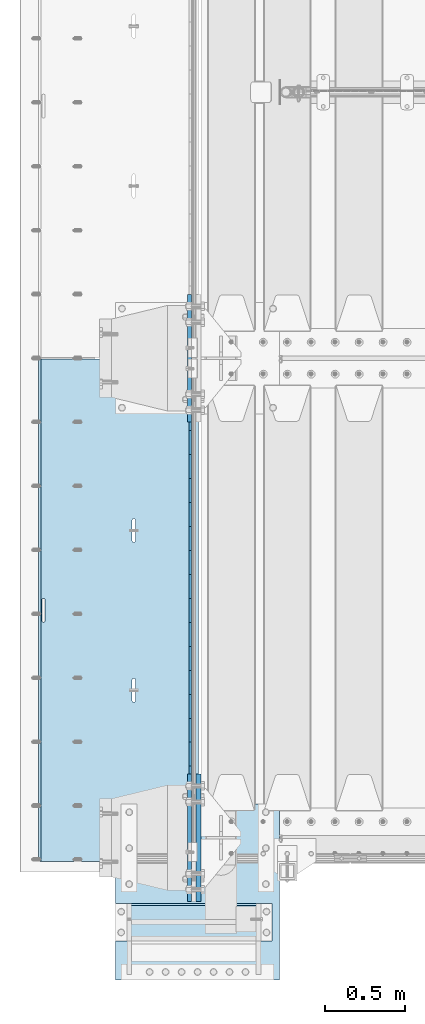
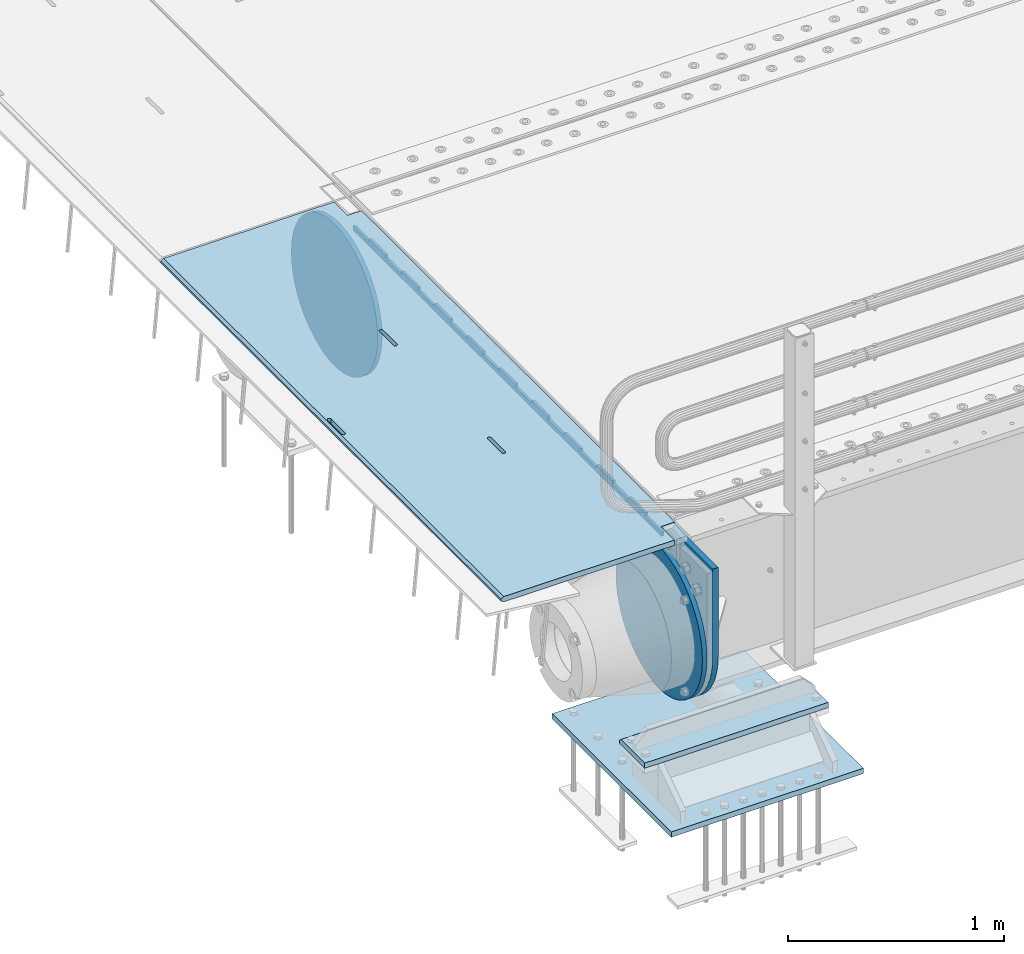
# One storey, part 161 of 208: 7 plates.
"""IFC2X3 building model written with IfcOpenShell, lengths in millimetres."""

from ifc_helpers import new_model, si_unit, frame, origin_with_axes, place, context, subcontext, project, spatial, faceted_brep, material, type_object, element, save


model = new_model("IFC2X3")

# Units and contexts
model_context = context("Model", 3, precision=1e-05, world=origin_with_axes())
body_context = subcontext(model_context, "Body", "Model", "MODEL_VIEW")
ifc_project = project(units=[si_unit("LENGTHUNIT", "METRE", prefix="MILLI"), si_unit("AREAUNIT", "SQUARE_METRE"), si_unit("VOLUMEUNIT", "CUBIC_METRE"), si_unit("MASSUNIT", "GRAM", prefix="KILO"), si_unit("TIMEUNIT", "SECOND"), si_unit("PLANEANGLEUNIT", "RADIAN"), si_unit("SOLIDANGLEUNIT", "STERADIAN"), si_unit("THERMODYNAMICTEMPERATUREUNIT", "DEGREE_CELSIUS"), si_unit("LUMINOUSINTENSITYUNIT", "LUMEN")], contexts=[model_context])

# Site, building, storey
site_placement = place(None, origin_with_axes())
site = spatial("IfcSite", under=ifc_project, at=site_placement, CompositionType="ELEMENT")
building_placement = place(site_placement, origin_with_axes())
building = spatial("IfcBuilding", under=site, at=building_placement, Name="Standard", CompositionType="ELEMENT")
storey_placement = place(building_placement, origin_with_axes())
storey = spatial("IfcBuildingStorey", under=building, at=storey_placement, Name="Undefined", CompositionType="ELEMENT", Elevation=0.0)

# Plates
ifc_material_1 = material(Name="STEEL/S355N")
plate_type_1 = type_object("IfcPlateType", PredefinedType="NOTDEFINED")
plate_1_placement = place(storey_placement, frame((-42455.0037545707, 2994.99992612933, -0.984410850183148), z_axis=(1.0000003385235e-09, -0.999999999987744, -4.95099999993936e-06), x_axis=(-0.999999999879068, -1.00000022173607e-09, -1.55519999981193e-05)))
element("IfcPlate", 1, at=plate_1_placement, inside=storey, type_object=plate_type_1, material=ifc_material_1, context=body_context, shape_type="Brep", body=[
    faceted_brep([(984.996459961352, -15.0, 1.81898940354586e-12), (999.996459960938, -4.99999999999848, 1.36424205265939e-12), (999.996459718779, -4.99999999999848, 3145.0), (984.996459719194, -15.0, 3145.0), (999.996459960938, 5.0, 1.81898940354586e-12), (984.996459960938, 15.0, 1.36424205265939e-12), (984.996459718779, 15.0, 3145.0), (999.996459718779, 5.0, 3145.0), (14.9998601691623, 15.0, 125.000024820844), (-0.000294611330900807, -0.000806902962786349, 124.999936248646), (-0.00191941577941179, 0.000806844426833264, 3020.00000492305), (14.9966216875036, 15.0, 3020.00007976653), (394.996621756974, -15.0000000032171, 2137.49999999767), (394.996621756974, 15.0, 2137.49999999767), (395.486056593785, 15.0, 2140.59016994142), (395.486056593785, -15.0000000032097, 2140.59016994142), (396.906451812771, 15.0, 2143.3778525206), (396.906451812763, -15.0000000031847, 2143.3778525206), (399.118769233428, 15.0, 2145.59016994142), (399.118769233428, -15.0000000031445, 2145.59016994142), (401.90645181248, 15.0, 2147.01056516062), (401.906451812487, -15.0000000030931, 2147.01056516062), (404.996621756189, 15.0, 2147.49999999767), (404.996621756189, -15.0000000030354, 2147.49999999767), (408.086791699985, 15.0, 2147.01056516062), (408.086791699985, -15.0000000029771, 2147.01056516062), (410.87447427927, 15.0, 2145.59016994142), (410.874474279262, -15.000000002924, 2145.59016994142), (413.086791700269, 15.0, 2143.37785252059), (413.086791700269, -15.0000000028812, 2143.37785252059), (414.507186919676, 15.0, 2140.59016994141), (414.507186919684, -15.000000002853, 2140.59016994141), (414.996621756967, 15.0, 2137.49999999766), (414.996621756967, -15.000000002842, 2137.49999999766), (414.996621766863, 15.0, 2007.49999999766), (414.996621766863, -15.0000000027658, 2007.49999999766), (414.507186930052, 15.0, 2004.40983005391), (414.507186930052, -15.0000000027732, 2004.40983005391), (413.086791711074, 15.0, 2001.62214747474), (413.086791711066, -15.0000000027982, 2001.62214747474), (410.874474290409, 15.0, 1999.40983005392), (410.874474290409, -15.0000000028384, 1999.40983005392), (408.08679171135, 15.0, 1997.98943483472), (408.08679171135, -15.0000000028898, 1997.98943483472), (404.99662176775, 15.0, 1997.49999999767), (404.996621767757, -15.0000000029475, 1997.49999999767), (401.906451823961, 15.0, 1997.98943483472), (401.906451823961, -15.0000000030058, 1997.98943483472), (399.118769244684, 15.0, 1999.40983005392), (399.118769244684, -15.0000000030589, 1999.40983005392), (396.906451823692, 15.0, 2001.62214747475), (396.906451823685, -15.0000000031017, 2001.62214747475), (395.486056604263, 15.0, 2004.40983005392), (395.486056604263, -15.0000000031299, 2004.40983005392), (394.996621766972, 15.0, 2007.49999999767), (394.996621766979, -15.0000000031409, 2007.49999999767), (-0.000449375191237777, -14.9999999951863, 124.999861417758), (-0.00046036208368605, -15.00000004538, 3019.99993008592), (75.0001087166966, 15.0, 125.000079754114), (74.999642186689, -15.0, 124.999930084114), (74.9997820615899, -15.0, 0.0), (75.0002485915829, 15.0, -4.54747350886464e-13), (74.9967306509934, 15.0, 3145.0), (74.9962640909944, -15.0, 3145.0), (74.9968705258798, 15.0, 3020.00007982413), (74.9964039658807, -14.999999998652, 3019.99993015413), (395.486056681264, -14.9999999992789, 1004.4098300544), (395.486056681264, 15.0, 1004.4098300544), (394.99662184398, 15.0, 1007.49999999815), (394.996621843988, -14.999999999278, 1007.49999999815), (396.906451900679, -14.999999999282, 1001.62214747523), (396.906451900686, 15.0, 1001.62214747523), (399.118769321678, -14.999999999287, 999.409830054401), (399.118769321678, 15.0, 999.409830054401), (401.906451900963, -14.9999999992934, 997.989434835199), (401.906451900963, 15.0, 997.989434835199), (404.996621844752, -14.9999999993006, 997.499999998151), (404.996621844744, 15.0, 997.499999998151), (408.086791788344, -14.9999999993078, 997.989434835199), (408.086791788344, 15.0, 997.989434835199), (410.874474367411, -14.9999999993143, 999.409830054399), (410.874474367403, 15.0, 999.409830054399), (413.086791788068, -14.9999999993196, 1001.62214747522), (413.086791788068, 15.0, 1001.62214747522), (414.507187007061, -14.999999999323, 1004.4098300544), (414.507187007061, 15.0, 1004.40983005439), (414.996621843871, -14.9999999993243, 1007.49999999814), (414.996621843871, 15.0, 1007.49999999814), (414.996621833961, -14.9999999993318, 1137.49999999814), (414.996621833961, 15.0, 1137.49999999814), (414.507186996678, -14.9999999993308, 1140.59016994189), (414.507186996678, 15.0, 1140.59016994189), (413.08679177727, -14.9999999993277, 1143.37785252107), (413.08679177727, 15.0, 1143.37785252107), (410.874474356264, -14.9999999993227, 1145.5901699419), (410.874474356264, 15.0, 1145.5901699419), (408.086791776987, -14.9999999993163, 1147.0105651611), (408.086791776987, 15.0, 1147.0105651611), (404.996621833197, -14.9999999993092, 1147.49999999815), (404.996621833197, 15.0, 1147.49999999815), (401.906451889496, -14.999999999302, 1147.0105651611), (401.906451889488, 15.0, 1147.0105651611), (399.118769310422, -14.9999999992955, 1145.5901699419), (399.118769310422, 15.0, 1145.5901699419), (396.906451889765, -14.9999999992902, 1143.37785252108), (396.906451889772, 15.0, 1143.37785252108), (395.486056670779, -14.9999999992867, 1140.5901699419), (395.486056670787, 15.0, 1140.5901699419), (394.996621833969, -14.9999999992854, 1137.49999999815), (394.996621833976, 15.0, 1137.49999999815), (960.486056632282, -15.0000000006253, 1640.59016994165), (961.906451851275, -15.0000000006287, 1643.37785252083), (964.118769271932, -15.000000000634, 1645.59016994165), (966.906451851006, -15.0000000006405, 1647.01056516085), (969.996621794693, -15.0000000006477, 1647.4999999979), (973.086791738489, -15.0000000006548, 1647.01056516085), (975.874474317781, -15.0000000006612, 1645.59016994165), (978.086791738773, -15.0000000006662, 1643.37785252082), (979.507186958181, -15.0000000006694, 1640.59016994164), (979.996621795464, -15.0000000006703, 1637.49999999789), (979.996621805367, -15.0000000006628, 1507.49999999789), (979.507186968556, -15.0000000006615, 1504.40983005415), (978.086791749571, -15.0000000006581, 1501.62214747497), (975.874474328928, -15.0000000006528, 1499.40983005415), (973.086791749854, -15.0000000006463, 1497.98943483495), (969.996621806255, -15.0000000006391, 1497.4999999979), (966.90645186248, -15.0000000006319, 1497.98943483495), (964.118769283188, -15.0000000006256, 1499.40983005415), (961.906451862189, -15.0000000006206, 1501.62214747498), (960.486056642767, -15.0000000006174, 1504.40983005415), (959.996621805491, -15.0000000006165, 1507.4999999979), (959.996621795472, -15.000000000624, 1637.4999999979), (961.906451862189, 15.0, 1501.62214747498), (960.486056642767, 15.0, 1504.40983005415), (964.118769283188, 15.0, 1499.40983005415), (966.90645186248, 15.0, 1497.98943483495), (969.996621806247, 15.0, 1497.4999999979), (973.086791749854, 15.0, 1497.98943483495), (975.874474328921, 15.0, 1499.40983005415), (978.086791749571, 15.0, 1501.62214747497), (979.507186968556, 15.0, 1504.40983005415), (979.996621805367, 15.0, 1507.49999999789), (979.996621795464, 15.0, 1637.49999999789), (979.507186958181, 15.0, 1640.59016994164), (978.086791738773, 15.0, 1643.37785252082), (975.874474317781, 15.0, 1645.59016994165), (973.086791738489, 15.0, 1647.01056516085), (969.9966217947, 15.0, 1647.4999999979), (966.906451850999, 15.0, 1647.01056516085), (964.118769271932, 15.0, 1645.59016994165), (961.906451851275, 15.0, 1643.37785252083), (960.486056632282, 15.0, 1640.59016994165), (959.996621795472, 15.0, 1637.4999999979), (959.996621805483, 15.0, 1507.4999999979)], [[[0, 1, 2, 3]], [[4, 5, 6, 7]], [[8, 9, 10, 11]], [[12, 13, 14, 15]], [[15, 14, 16, 17]], [[17, 16, 18, 19]], [[19, 18, 20, 21]], [[21, 20, 22, 23]], [[23, 22, 24, 25]], [[25, 24, 26, 27]], [[27, 26, 28, 29]], [[29, 28, 30, 31]], [[31, 30, 32, 33]], [[33, 32, 34, 35]], [[35, 34, 36, 37]], [[37, 36, 38, 39]], [[39, 38, 40, 41]], [[41, 40, 42, 43]], [[43, 42, 44, 45]], [[45, 44, 46, 47]], [[47, 46, 48, 49]], [[49, 48, 50, 51]], [[51, 50, 52, 53]], [[53, 52, 54, 55]], [[55, 54, 13, 12]], [[56, 57, 10, 9]], [[58, 59, 56, 9, 8]], [[60, 59, 58, 61]], [[60, 61, 5, 4, 1, 0]], [[4, 7, 2, 1]], [[7, 6, 62, 63, 3, 2]], [[63, 62, 64, 65]], [[57, 65, 64, 11, 10]], [[66, 67, 68, 69]], [[70, 71, 67, 66]], [[72, 73, 71, 70]], [[74, 75, 73, 72]], [[76, 77, 75, 74]], [[78, 79, 77, 76]], [[80, 81, 79, 78]], [[82, 83, 81, 80]], [[84, 85, 83, 82]], [[86, 87, 85, 84]], [[88, 89, 87, 86]], [[90, 91, 89, 88]], [[92, 93, 91, 90]], [[94, 95, 93, 92]], [[96, 97, 95, 94]], [[98, 99, 97, 96]], [[100, 101, 99, 98]], [[102, 103, 101, 100]], [[104, 105, 103, 102]], [[106, 107, 105, 104]], [[108, 109, 107, 106]], [[69, 68, 109, 108]], [[63, 65, 57, 56, 59, 60, 0, 3], [15, 17, 19, 21, 23, 25, 27, 29, 31, 33, 35, 37, 39, 41, 43, 45, 47, 49, 51, 53, 55, 12], [106, 104, 102, 100, 98, 96, 94, 92, 90, 88, 86, 84, 82, 80, 78, 76, 74, 72, 70, 66, 69, 108], [110, 111, 112, 113, 114, 115, 116, 117, 118, 119, 120, 121, 122, 123, 124, 125, 126, 127, 128, 129, 130, 131]], [[128, 132, 133, 129]], [[127, 134, 132, 128]], [[126, 135, 134, 127]], [[125, 136, 135, 126]], [[124, 137, 136, 125]], [[123, 138, 137, 124]], [[122, 139, 138, 123]], [[121, 140, 139, 122]], [[120, 141, 140, 121]], [[119, 142, 141, 120]], [[118, 143, 142, 119]], [[117, 144, 143, 118]], [[116, 145, 144, 117]], [[115, 146, 145, 116]], [[114, 147, 146, 115]], [[113, 148, 147, 114]], [[112, 149, 148, 113]], [[111, 150, 149, 112]], [[110, 151, 150, 111]], [[131, 152, 151, 110]], [[130, 153, 152, 131]], [[129, 133, 153, 130]], [[61, 58, 8, 11, 64, 62, 6, 5], [50, 48, 46, 44, 42, 40, 38, 36, 34, 32, 30, 28, 26, 24, 22, 20, 18, 16, 14, 13, 54, 52], [132, 134, 135, 136, 137, 138, 139, 140, 141, 142, 143, 144, 145, 146, 147, 148, 149, 150, 151, 152, 153, 133], [71, 73, 75, 77, 79, 81, 83, 85, 87, 89, 91, 93, 95, 97, 99, 101, 103, 105, 107, 109, 68, 67]]]),
])
plate_type_2 = type_object("IfcPlateType", PredefinedType="NOTDEFINED")
plate_2_placement = place(storey_placement, frame((-42507.5, 2847.50009937252, -35.9858217390411), z_axis=(1.0000003385235e-09, -0.999999999987744, -4.95099999993936e-06), x_axis=(0.0, 4.95099999111973e-06, -0.999999999987744)))
element("IfcPlate", 2, at=plate_2_placement, inside=storey, type_object=plate_type_2, material=ifc_material_1, context=body_context, shape_type="Brep", body=[
    faceted_brep([(0.0, -7.5, -4.54747350886464e-13), (5.96145355302724e-12, -7.5, 150.0), (5.96145355302724e-12, 7.5, 150.0), (0.0, 7.5, -4.54747350886464e-13), (-15.0000000000013, -7.5, 150.0), (-15.0000000000013, 7.5, 150.0), (-15.0000000000026, -7.5, 300.0), (-15.0000000000026, 7.5, 300.0), (1.00826014204358e-11, -7.5, 300.0), (1.00826014204358e-11, 7.5, 300.0), (1.05870867628255e-11, -7.5, 450.0), (1.05870867628255e-11, 7.5, 450.0), (-15.000000000004, -7.5, 450.0), (-15.000000000004, 7.5, 450.0), (-15.0000000000053, -7.5, 600.0), (-15.0000000000053, 7.5, 600.0), (1.65343294611375e-11, -7.5, 600.0), (1.65343294611375e-11, 7.5, 600.0), (1.88506987797155e-11, -7.5, 750.0), (1.88506987797155e-11, 7.5, 750.0), (-15.0000000000066, -7.5, 750.0), (-15.0000000000066, 7.5, 750.0), (-15.0000000000079, -7.5, 900.0), (-15.0000000000079, 7.5, 900.0), (2.48050469053851e-11, -7.5, 900.0), (2.48050469053851e-11, 7.5, 900.0), (2.7121416223963e-11, -7.5, 1050.0), (2.7121416223963e-11, 7.5, 1050.0), (-15.0000000000093, -7.5, 1050.0), (-15.0000000000093, 7.5, 1050.0), (-15.0000000000106, -7.5, 1200.0), (-15.0000000000106, 7.5, 1200.0), (3.12638803734444e-11, -7.5, 1200.0), (3.12638803734444e-11, 7.5, 1200.0), (3.53921336682106e-11, -7.5, 1350.0), (3.53921336682106e-11, 7.5, 1350.0), (-15.0000000000119, -7.5, 1350.0), (-15.0000000000119, 7.5, 1350.0), (-15.0000000000132, -7.5, 1500.0), (-15.0000000000132, 7.5, 1500.0), (3.77085029867885e-11, -7.5, 1500.0), (3.77085029867885e-11, 7.5, 1500.0), (4.36628511124582e-11, -7.5, 1650.0), (4.36628511124582e-11, 7.5, 1650.0), (-15.0000000000145, -7.5, 1650.0), (-15.0000000000145, 7.5, 1650.0), (-15.0000000000159, -7.5, 1800.0), (-15.0000000000159, 7.5, 1800.0), (4.41531256001326e-11, -7.5, 1800.0), (4.41531256001326e-11, 7.5, 1800.0), (4.82884843222564e-11, -7.5, 1950.0), (4.82884843222564e-11, 7.5, 1950.0), (-15.0000000000172, -7.5, 1950.0), (-15.0000000000172, 7.5, 1950.0), (-15.0000000000185, -7.5, 2100.0), (-15.0000000000185, 7.5, 2100.0), (5.24309484717378e-11, -7.5, 2100.0), (5.24309484717378e-11, 7.5, 2100.0), (5.47402123629581e-11, -7.5, 2250.0), (5.47402123629581e-11, 7.5, 2250.0), (-15.0000000000198, -7.5, 2250.0), (-15.0000000000198, 7.5, 2250.0), (-15.0000000000212, -7.5, 2400.0), (-15.0000000000212, 7.5, 2400.0), (6.06945604886278e-11, -7.5, 2400.0), (6.06945604886278e-11, 7.5, 2400.0), (6.30038243798481e-11, -7.5, 2550.0), (6.30038243798481e-11, 7.5, 2550.0), (-15.0000000000225, -7.5, 2550.0), (-15.0000000000225, 7.5, 2550.0), (-15.0000000000238, -7.5, 2700.0), (-15.0000000000238, 7.5, 2700.0), (6.53272991257836e-11, -7.5, 2700.0), (6.53272991257836e-11, 7.5, 2700.0), (7.12745418240957e-11, -7.5, 2850.0), (7.12745418240957e-11, 7.5, 2850.0), (24.9999999999749, -7.5, 2850.0), (24.9999999999749, 7.5, 2850.0), (25.0, -7.5, -2.27373675443232e-12), (25.0, 7.5, -2.27373675443232e-12)], [[[0, 1, 2, 3]], [[1, 4, 5, 2]], [[4, 6, 7, 5]], [[6, 8, 9, 7]], [[8, 10, 11, 9]], [[10, 12, 13, 11]], [[12, 14, 15, 13]], [[14, 16, 17, 15]], [[16, 18, 19, 17]], [[18, 20, 21, 19]], [[20, 22, 23, 21]], [[22, 24, 25, 23]], [[24, 26, 27, 25]], [[26, 28, 29, 27]], [[28, 30, 31, 29]], [[30, 32, 33, 31]], [[32, 34, 35, 33]], [[34, 36, 37, 35]], [[36, 38, 39, 37]], [[38, 40, 41, 39]], [[40, 42, 43, 41]], [[42, 44, 45, 43]], [[44, 46, 47, 45]], [[46, 48, 49, 47]], [[48, 50, 51, 49]], [[50, 52, 53, 51]], [[52, 54, 55, 53]], [[54, 56, 57, 55]], [[56, 58, 59, 57]], [[58, 60, 61, 59]], [[60, 62, 63, 61]], [[62, 64, 65, 63]], [[64, 66, 67, 65]], [[66, 68, 69, 67]], [[68, 70, 71, 69]], [[70, 72, 73, 71]], [[72, 74, 75, 73]], [[74, 76, 77, 75]], [[76, 78, 79, 77]], [[78, 0, 3, 79]], [[5, 7, 9, 11, 13, 15, 17, 19, 21, 23, 25, 27, 29, 31, 33, 35, 37, 39, 41, 43, 45, 47, 49, 51, 53, 55, 57, 59, 61, 63, 65, 67, 69, 71, 73, 75, 77, 79, 3, 2]], [[78, 76, 74, 72, 70, 68, 66, 64, 62, 60, 58, 56, 54, 52, 50, 48, 46, 44, 42, 40, 38, 36, 34, 32, 30, 28, 26, 24, 22, 20, 18, 16, 14, 12, 10, 8, 6, 4, 1, 0]]]),
])
plate_type_3 = type_object("IfcPlateType", PredefinedType="NOTDEFINED")
plate_3_placement = place(storey_placement, frame((-42455.0, -400.0, -20.0), z_axis=(0.0, 1.0, 0.0), x_axis=(0.0, 0.0, -1.0)))
element("IfcPlate", 3, at=plate_3_placement, inside=storey, type_object=plate_type_3, material=ifc_material_1, context=body_context, shape_type="Brep", body=[
    faceted_brep([(855.0, -15.0, 572.963114671446), (855.0, 15.0, 572.963114671446), (849.182410261259, 15.0, 585.889268817516), (849.182410261259, -15.0, 585.889268817516), (824.193546357442, 15.0, 627.225898692465), (824.193546357442, -15.0, 627.225898692465), (794.404299268426, 15.0, 665.249063296316), (794.404299268426, -15.0, 665.249063296316), (760.249063296309, 15.0, 699.404299268435), (760.249063296309, -15.0, 699.404299268435), (722.22589869246, 15.0, 729.193546357455), (722.22589869246, -15.0, 729.193546357455), (680.889268817512, 15.0, 754.182410261274), (680.889268817512, -15.0, 754.182410261274), (636.841954817025, 15.0, 774.006497074155), (636.841954817025, -15.0, 774.006497074155), (590.726265715041, 15.0, 788.37672697041), (590.726265715041, -15.0, 788.37672697041), (543.214672102153, 15.0, 797.083549639213), (543.214672102153, -15.0, 797.083549639213), (495.0, -15.0, 800.000000000029), (495.0, 15.0, 800.0), (494.999999999412, -15.0, 0.0), (494.999999999412, 15.0, 0.0), (543.214672102129, 15.0, 2.91645036080718), (543.214672102129, -15.0, 2.91645036080718), (590.726265715023, 15.0, 11.6232730296078), (590.726265715023, -15.0, 11.6232730296078), (636.841954817014, 15.0, 25.9935029258631), (636.841954817014, -15.0, 25.9935029258631), (680.889268817507, 15.0, 45.8175897387455), (680.889268817507, -15.0, 45.8175897387455), (722.225898692462, 15.0, 70.8064536425663), (722.225898692462, -15.0, 70.8064536425663), (760.249063296318, 15.0, 100.595700731588), (760.249063296318, -15.0, 100.595700731588), (794.404299268441, 15.0, 134.750936703711), (794.404299268441, -15.0, 134.750936703711), (824.193546357463, 15.0, 172.774101307567), (824.193546357463, -15.0, 172.774101307567), (849.182410261284, 15.0, 214.110731182522), (849.182410261284, -15.0, 214.110731182522), (855.0, -15.0, 227.036885328535), (855.0, 15.0, 227.036885328535), (0.0, -15.0, 0.0), (0.0, 15.0, 0.0), (0.0, 15.0, 800.0), (0.0, -15.0, 800.0)], [[[0, 1, 2, 3]], [[3, 2, 4, 5]], [[5, 4, 6, 7]], [[7, 6, 8, 9]], [[9, 8, 10, 11]], [[11, 10, 12, 13]], [[13, 12, 14, 15]], [[15, 14, 16, 17]], [[17, 16, 18, 19]], [[20, 19, 18, 21]], [[22, 23, 24, 25]], [[25, 24, 26, 27]], [[27, 26, 28, 29]], [[29, 28, 30, 31]], [[31, 30, 32, 33]], [[33, 32, 34, 35]], [[35, 34, 36, 37]], [[37, 36, 38, 39]], [[39, 38, 40, 41]], [[42, 41, 40, 43]], [[42, 43, 1, 0]], [[44, 45, 23, 22]], [[16, 14, 12, 10, 8, 6, 4, 2, 1, 43, 40, 38, 36, 34, 32, 30, 28, 26, 24, 23, 45, 46, 21, 18]], [[44, 47, 46, 45]], [[46, 47, 20, 21]], [[47, 44, 22, 25, 27, 29, 31, 33, 35, 37, 39, 41, 42, 0, 3, 5, 7, 9, 11, 13, 15, 17, 19, 20]]]),
])
plate_type_4 = type_object("IfcPlateType", PredefinedType="NOTDEFINED")
plate_4_placement = place(storey_placement, frame((-42512.5, 3400.0, -114.999999999998), z_axis=(0.0, 0.0, -1.0), x_axis=(0.0, -1.0, 0.0)))
element("IfcPlate", 4, at=plate_4_placement, inside=storey, type_object=plate_type_4, material=ifc_material_1, context=body_context, shape_type="Brep", body=[
    faceted_brep([(0.0, -12.5, 400.0), (2.91645036078444, -12.5, 448.214672102168), (2.91645036078444, 12.5, 448.214672102168), (0.0, 12.5, 400.0), (11.6232730295887, -12.5, 495.726265715062), (11.6232730295887, 12.5, 495.726265715062), (25.9935029258468, -12.5, 541.841954817051), (25.9935029258468, 12.5, 541.841954817051), (45.81758973873, -12.5, 585.889268817542), (45.81758973873, 12.5, 585.889268817542), (70.8064536425536, -12.5, 627.225898692492), (70.8064536425536, 12.5, 627.225898692492), (100.595700731576, -12.5, 665.249063296343), (100.595700731576, 12.5, 665.249063296343), (134.750936703701, -12.5, 699.404299268459), (134.750936703701, 12.5, 699.404299268459), (172.774101307557, -12.5, 729.193546357476), (172.774101307557, 12.5, 729.193546357476), (214.110731182515, -12.5, 754.182410261292), (214.110731182515, 12.5, 754.182410261292), (258.158045183012, -12.5, 774.006497074168), (258.158045183012, 12.5, 774.006497074168), (304.273734285007, -12.5, 788.376726970419), (304.273734285007, 12.5, 788.376726970419), (351.785327897906, -12.5, 797.083549639215), (351.785327897906, 12.5, 797.083549639215), (400.0, -12.5, 800.0), (400.0, 12.5, 800.0), (448.214672102084, -12.5, 797.083549639379), (448.214672102084, 12.5, 797.083549639379), (495.726265714995, -12.5, 788.37672697056), (495.726265714995, 12.5, 788.37672697056), (541.841954817006, -12.5, 774.006497074283), (541.841954817006, 12.5, 774.006497074283), (585.889268817518, -12.5, 754.182410261379), (585.889268817518, 12.5, 754.182410261379), (627.225898692492, -12.5, 729.193546357534), (627.225898692492, 12.5, 729.193546357534), (665.249063296365, -12.5, 699.404299268488), (665.249063296365, 12.5, 699.404299268488), (699.404299268504, -12.5, 665.249063296339), (699.404299268504, 12.5, 665.249063296339), (729.193546357543, -12.5, 627.225898692458), (729.193546357543, 12.5, 627.225898692458), (754.182410261379, -12.5, 585.889268817477), (754.182410261379, 12.5, 585.889268817477), (774.006497074275, -12.5, 541.841954816959), (774.006497074275, 12.5, 541.841954816959), (788.376726970542, -12.5, 495.726265714942), (788.376726970542, 12.5, 495.726265714942), (797.083549639352, -12.5, 448.214672102024), (797.083549639352, 12.5, 448.214672102024), (800.0, -12.5, 400.0), (800.0, 12.5, 400.0), (797.083549639225, -12.5, 351.785327897849), (797.083549639225, 12.5, 351.785327897849), (788.376726970419, -12.5, 304.273734284957), (788.376726970419, 12.5, 304.273734284957), (774.006497074162, -12.5, 258.158045182969), (774.006497074162, 12.5, 258.158045182969), (754.182410261277, -12.5, 214.110731182482), (754.182410261277, 12.5, 214.110731182482), (729.193546357454, -12.5, 172.774101307534), (729.193546357454, 12.5, 172.774101307534), (699.40429926843, -12.5, 134.750936703684), (699.40429926843, 12.5, 134.750936703684), (665.249063296305, -12.5, 100.595700731569), (665.249063296305, 12.5, 100.595700731569), (627.225898692448, -12.5, 70.8064536425563), (627.225898692448, 12.5, 70.8064536425563), (585.889268817491, -12.5, 45.8175897387418), (585.889268817491, 12.5, 45.8175897387418), (541.841954816997, -12.5, 25.9935029258686), (541.841954816997, 12.5, 25.9935029258686), (495.726265715002, -12.5, 11.6232730296188), (495.726265715002, 12.5, 11.6232730296188), (448.214672102105, -12.5, 2.91645036082446), (448.214672102105, 12.5, 2.91645036082446), (400.0, -12.5, -5.6843418860808e-14), (400.0, 12.5, -5.6843418860808e-14), (351.785327897929, -12.5, 2.91645036063619), (351.785327897929, 12.5, 2.91645036063619), (304.273734285018, -12.5, 11.6232730294578), (304.273734285018, 12.5, 11.6232730294578), (258.158045183009, -12.5, 25.993502925734), (258.158045183009, 12.5, 25.993502925734), (214.110731182496, -12.5, 45.8175897386391), (214.110731182496, 12.5, 45.8175897386391), (172.774101307523, -12.5, 70.8064536424836), (172.774101307523, 12.5, 70.8064536424836), (134.750936703649, -12.5, 100.595700731531), (134.750936703649, 12.5, 100.595700731531), (100.595700731511, -12.5, 134.750936703678), (100.595700731511, 12.5, 134.750936703678), (70.8064536424727, -12.5, 172.774101307559), (70.8064536424727, 12.5, 172.774101307559), (45.8175897386354, -12.5, 214.110731182539), (45.8175897386354, 12.5, 214.110731182539), (25.9935029257394, -12.5, 258.158045183057), (25.9935029257394, 12.5, 258.158045183057), (11.6232730294714, -12.5, 304.273734285073), (11.6232730294714, 12.5, 304.273734285073), (2.91645036065893, -12.5, 351.78532789799), (2.91645036065893, 12.5, 351.78532789799)], [[[0, 1, 2, 3]], [[1, 4, 5, 2]], [[4, 6, 7, 5]], [[6, 8, 9, 7]], [[8, 10, 11, 9]], [[10, 12, 13, 11]], [[12, 14, 15, 13]], [[14, 16, 17, 15]], [[16, 18, 19, 17]], [[18, 20, 21, 19]], [[20, 22, 23, 21]], [[22, 24, 25, 23]], [[24, 26, 27, 25]], [[26, 28, 29, 27]], [[28, 30, 31, 29]], [[30, 32, 33, 31]], [[32, 34, 35, 33]], [[34, 36, 37, 35]], [[36, 38, 39, 37]], [[38, 40, 41, 39]], [[40, 42, 43, 41]], [[42, 44, 45, 43]], [[44, 46, 47, 45]], [[46, 48, 49, 47]], [[48, 50, 51, 49]], [[50, 52, 53, 51]], [[52, 54, 55, 53]], [[54, 56, 57, 55]], [[56, 58, 59, 57]], [[58, 60, 61, 59]], [[60, 62, 63, 61]], [[62, 64, 65, 63]], [[64, 66, 67, 65]], [[66, 68, 69, 67]], [[68, 70, 71, 69]], [[70, 72, 73, 71]], [[72, 74, 75, 73]], [[74, 76, 77, 75]], [[76, 78, 79, 77]], [[78, 80, 81, 79]], [[80, 82, 83, 81]], [[82, 84, 85, 83]], [[84, 86, 87, 85]], [[86, 88, 89, 87]], [[88, 90, 91, 89]], [[90, 92, 93, 91]], [[92, 94, 95, 93]], [[94, 96, 97, 95]], [[96, 98, 99, 97]], [[98, 100, 101, 99]], [[100, 102, 103, 101]], [[102, 0, 3, 103]], [[5, 7, 9, 11, 13, 15, 17, 19, 21, 23, 25, 27, 29, 31, 33, 35, 37, 39, 41, 43, 45, 47, 49, 51, 53, 55, 57, 59, 61, 63, 65, 67, 69, 71, 73, 75, 77, 79, 81, 83, 85, 87, 89, 91, 93, 95, 97, 99, 101, 103, 3, 2]], [[102, 100, 98, 96, 94, 92, 90, 88, 86, 84, 82, 80, 78, 76, 74, 72, 70, 68, 66, 64, 62, 60, 58, 56, 54, 52, 50, 48, 46, 44, 42, 40, 38, 36, 34, 32, 30, 28, 26, 24, 22, 20, 18, 16, 14, 12, 10, 8, 6, 4, 1, 0]]]),
])
plate_5_placement = place(storey_placement, frame((-42512.5, 400.0, -114.999999999998), z_axis=(0.0, 0.0, -1.0), x_axis=(0.0, -1.0, 0.0)))
element("IfcPlate", 5, at=plate_5_placement, inside=storey, type_object=plate_type_4, material=ifc_material_1, context=body_context, shape_type="Brep", body=[
    faceted_brep([(0.0, -12.5, 400.0), (2.91645036078444, -12.5, 448.214672102168), (2.91645036078444, 12.5, 448.214672102168), (0.0, 12.5, 400.0), (11.6232730295887, -12.5, 495.726265715062), (11.6232730295887, 12.5, 495.726265715062), (25.9935029258468, -12.5, 541.841954817051), (25.9935029258468, 12.5, 541.841954817051), (45.81758973873, -12.5, 585.889268817542), (45.81758973873, 12.5, 585.889268817542), (70.8064536425536, -12.5, 627.225898692492), (70.8064536425536, 12.5, 627.225898692492), (100.595700731576, -12.5, 665.249063296343), (100.595700731576, 12.5, 665.249063296343), (134.750936703701, -12.5, 699.404299268459), (134.750936703701, 12.5, 699.404299268459), (172.774101307557, -12.5, 729.193546357476), (172.774101307557, 12.5, 729.193546357476), (214.110731182515, -12.5, 754.182410261292), (214.110731182515, 12.5, 754.182410261292), (258.158045183012, -12.5, 774.006497074168), (258.158045183012, 12.5, 774.006497074168), (304.273734285007, -12.5, 788.376726970419), (304.273734285007, 12.5, 788.376726970419), (351.785327897906, -12.5, 797.083549639215), (351.785327897906, 12.5, 797.083549639215), (400.0, -12.5, 800.0), (400.0, 12.5, 800.0), (448.214672102084, -12.5, 797.083549639379), (448.214672102084, 12.5, 797.083549639379), (495.726265714995, -12.5, 788.37672697056), (495.726265714995, 12.5, 788.37672697056), (541.841954817006, -12.5, 774.006497074283), (541.841954817006, 12.5, 774.006497074283), (585.889268817518, -12.5, 754.182410261379), (585.889268817518, 12.5, 754.182410261379), (627.225898692492, -12.5, 729.193546357534), (627.225898692492, 12.5, 729.193546357534), (665.249063296365, -12.5, 699.404299268488), (665.249063296365, 12.5, 699.404299268488), (699.404299268504, -12.5, 665.249063296339), (699.404299268504, 12.5, 665.249063296339), (729.193546357543, -12.5, 627.225898692458), (729.193546357543, 12.5, 627.225898692458), (754.182410261379, -12.5, 585.889268817477), (754.182410261379, 12.5, 585.889268817477), (774.006497074275, -12.5, 541.841954816959), (774.006497074275, 12.5, 541.841954816959), (788.376726970542, -12.5, 495.726265714942), (788.376726970542, 12.5, 495.726265714942), (797.083549639352, -12.5, 448.214672102024), (797.083549639352, 12.5, 448.214672102024), (800.0, -12.5, 400.0), (800.0, 12.5, 400.0), (797.083549639225, -12.5, 351.785327897849), (797.083549639225, 12.5, 351.785327897849), (788.376726970419, -12.5, 304.273734284957), (788.376726970419, 12.5, 304.273734284957), (774.006497074162, -12.5, 258.158045182969), (774.006497074162, 12.5, 258.158045182969), (754.182410261277, -12.5, 214.110731182482), (754.182410261277, 12.5, 214.110731182482), (729.193546357454, -12.5, 172.774101307534), (729.193546357454, 12.5, 172.774101307534), (699.40429926843, -12.5, 134.750936703684), (699.40429926843, 12.5, 134.750936703684), (665.249063296305, -12.5, 100.595700731569), (665.249063296305, 12.5, 100.595700731569), (627.225898692448, -12.5, 70.8064536425563), (627.225898692448, 12.5, 70.8064536425563), (585.889268817491, -12.5, 45.8175897387418), (585.889268817491, 12.5, 45.8175897387418), (541.841954816997, -12.5, 25.9935029258686), (541.841954816997, 12.5, 25.9935029258686), (495.726265715002, -12.5, 11.6232730296188), (495.726265715002, 12.5, 11.6232730296188), (448.214672102105, -12.5, 2.91645036082446), (448.214672102105, 12.5, 2.91645036082446), (400.0, -12.5, -5.6843418860808e-14), (400.0, 12.5, -5.6843418860808e-14), (351.785327897929, -12.5, 2.91645036063619), (351.785327897929, 12.5, 2.91645036063619), (304.273734285018, -12.5, 11.6232730294578), (304.273734285018, 12.5, 11.6232730294578), (258.158045183009, -12.5, 25.993502925734), (258.158045183009, 12.5, 25.993502925734), (214.110731182496, -12.5, 45.8175897386391), (214.110731182496, 12.5, 45.8175897386391), (172.774101307523, -12.5, 70.8064536424836), (172.774101307523, 12.5, 70.8064536424836), (134.750936703649, -12.5, 100.595700731531), (134.750936703649, 12.5, 100.595700731531), (100.595700731511, -12.5, 134.750936703678), (100.595700731511, 12.5, 134.750936703678), (70.8064536424727, -12.5, 172.774101307559), (70.8064536424727, 12.5, 172.774101307559), (45.8175897386354, -12.5, 214.110731182539), (45.8175897386354, 12.5, 214.110731182539), (25.9935029257394, -12.5, 258.158045183057), (25.9935029257394, 12.5, 258.158045183057), (11.6232730294714, -12.5, 304.273734285073), (11.6232730294714, 12.5, 304.273734285073), (2.91645036065893, -12.5, 351.78532789799), (2.91645036065893, 12.5, 351.78532789799)], [[[0, 1, 2, 3]], [[1, 4, 5, 2]], [[4, 6, 7, 5]], [[6, 8, 9, 7]], [[8, 10, 11, 9]], [[10, 12, 13, 11]], [[12, 14, 15, 13]], [[14, 16, 17, 15]], [[16, 18, 19, 17]], [[18, 20, 21, 19]], [[20, 22, 23, 21]], [[22, 24, 25, 23]], [[24, 26, 27, 25]], [[26, 28, 29, 27]], [[28, 30, 31, 29]], [[30, 32, 33, 31]], [[32, 34, 35, 33]], [[34, 36, 37, 35]], [[36, 38, 39, 37]], [[38, 40, 41, 39]], [[40, 42, 43, 41]], [[42, 44, 45, 43]], [[44, 46, 47, 45]], [[46, 48, 49, 47]], [[48, 50, 51, 49]], [[50, 52, 53, 51]], [[52, 54, 55, 53]], [[54, 56, 57, 55]], [[56, 58, 59, 57]], [[58, 60, 61, 59]], [[60, 62, 63, 61]], [[62, 64, 65, 63]], [[64, 66, 67, 65]], [[66, 68, 69, 67]], [[68, 70, 71, 69]], [[70, 72, 73, 71]], [[72, 74, 75, 73]], [[74, 76, 77, 75]], [[76, 78, 79, 77]], [[78, 80, 81, 79]], [[80, 82, 83, 81]], [[82, 84, 85, 83]], [[84, 86, 87, 85]], [[86, 88, 89, 87]], [[88, 90, 91, 89]], [[90, 92, 93, 91]], [[92, 94, 95, 93]], [[94, 96, 97, 95]], [[96, 98, 99, 97]], [[98, 100, 101, 99]], [[100, 102, 103, 101]], [[102, 0, 3, 103]], [[5, 7, 9, 11, 13, 15, 17, 19, 21, 23, 25, 27, 29, 31, 33, 35, 37, 39, 41, 43, 45, 47, 49, 51, 53, 55, 57, 59, 61, 63, 65, 67, 69, 71, 73, 75, 77, 79, 81, 83, 85, 87, 89, 91, 93, 95, 97, 99, 101, 103, 3, 2]], [[102, 100, 98, 96, 94, 92, 90, 88, 86, 84, 82, 80, 78, 76, 74, 72, 70, 68, 66, 64, 62, 60, 58, 56, 54, 52, 50, 48, 46, 44, 42, 40, 38, 36, 34, 32, 30, 28, 26, 24, 22, 20, 18, 16, 14, 12, 10, 8, 6, 4, 1, 0]]]),
])
ifc_material_2 = material()
plate_type_5 = type_object("IfcPlateType", PredefinedType="NOTDEFINED")
plate_6_placement = place(storey_placement, frame((-41995.0, -645.0, -803.000000000004), z_axis=(0.0, 1.0, 0.0), x_axis=(-1.0, 0.0, 0.0)))
element("IfcPlate", 6, at=plate_6_placement, inside=storey, type_object=plate_type_5, material=ifc_material_2, context=body_context, shape_type="Brep", body=[
    faceted_brep([(979.0, 0.0, 235.0), (979.0, 15.0, 220.0), (0.0, 15.0, 220.0), (0.0, 0.0, 235.0), (0.0, 15.0, 0.0), (0.0, -15.0, 0.0), (0.0, -15.0, 235.0), (979.0, -15.0, 235.0), (979.0, -15.0, 0.0), (979.0, 15.0, 0.0)], [[[0, 1, 2, 3]], [[4, 5, 6, 3, 2]], [[6, 7, 0, 3]], [[7, 8, 9, 1, 0]], [[8, 5, 4, 9]], [[9, 4, 2, 1]], [[8, 7, 6, 5]]]),
])
plate_type_6 = type_object("IfcPlateType", PredefinedType="NOTDEFINED")
plate_7_placement = place(storey_placement, frame((-42974.0, -890.0, -1043.0), z_axis=(1.0, 0.0, 0.0), x_axis=(0.0, 1.0, 0.0)))
element("IfcPlate", 7, at=plate_7_placement, inside=storey, type_object=plate_type_6, material=ifc_material_2, context=body_context, shape_type="Brep", body=[
    faceted_brep([(0.0, -15.0, 0.0), (2.93249104288407e-06, -15.0, 1025.0), (2.93249104288407e-06, 15.0, 1025.0), (0.0, 15.0, 0.0), (1100.0, -15.0, 1025.0), (1100.0, 15.0, 1025.0), (1100.0, -15.0, -2.18278728425503e-11), (1100.0, 15.0, -2.18278728425503e-11)], [[[0, 1, 2, 3]], [[1, 4, 5, 2]], [[4, 6, 7, 5]], [[6, 0, 3, 7]], [[5, 7, 3, 2]], [[6, 4, 1, 0]]]),
])

save(model, "model.ifc")
